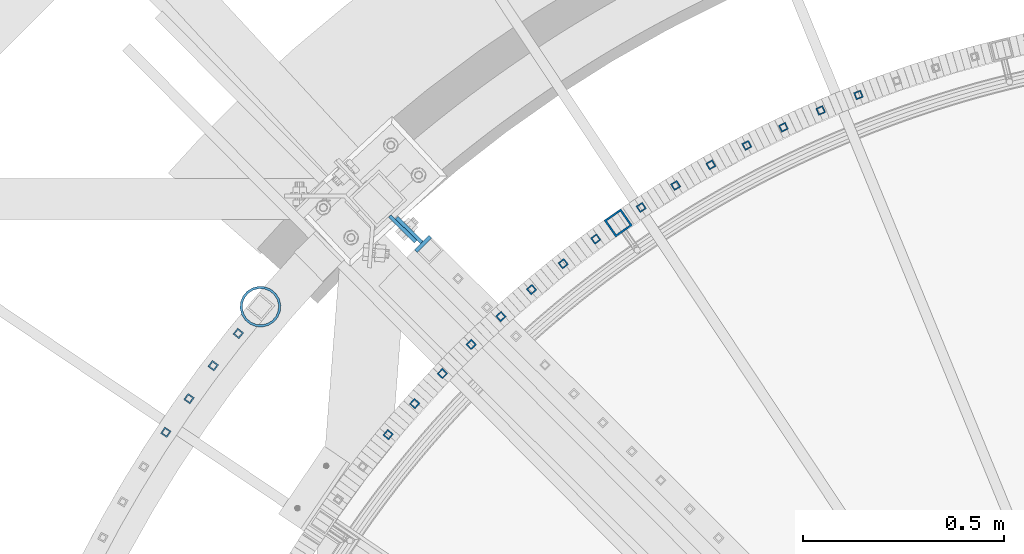
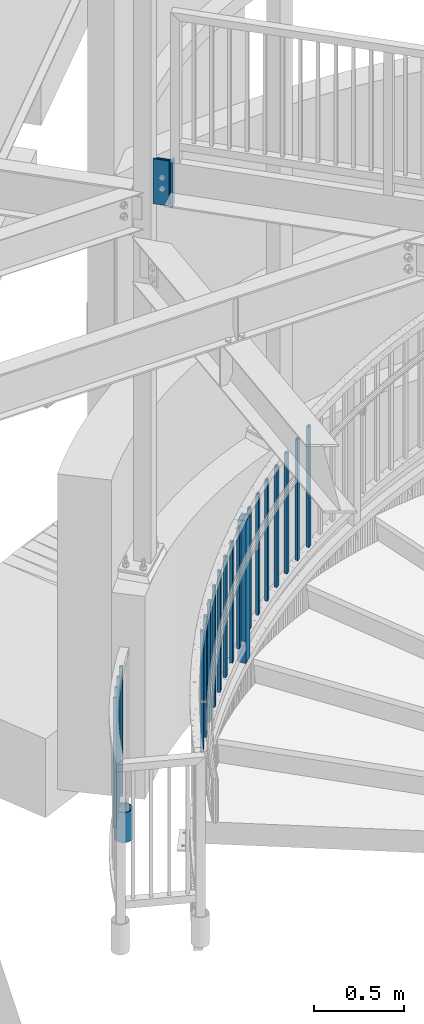
# One storey, part 263 of 975: 24 columns.
"""IFC2X3 building model written with IfcOpenShell, lengths in millimetres."""

from ifc_helpers import new_model, si_unit, frame, origin_with_axes, place, context, subcontext, project, spatial, faceted_brep, material, type_object, element, save


model = new_model("IFC2X3")

# Units and contexts
model_context = context("Model", 3, precision=1e-05, world=origin_with_axes())
body_context = subcontext(model_context, "Body", "Model", "MODEL_VIEW")
ifc_project = project(units=[si_unit("LENGTHUNIT", "METRE", prefix="MILLI"), si_unit("AREAUNIT", "SQUARE_METRE"), si_unit("VOLUMEUNIT", "CUBIC_METRE"), si_unit("MASSUNIT", "GRAM", prefix="KILO"), si_unit("TIMEUNIT", "SECOND"), si_unit("PLANEANGLEUNIT", "RADIAN"), si_unit("SOLIDANGLEUNIT", "STERADIAN"), si_unit("THERMODYNAMICTEMPERATUREUNIT", "DEGREE_CELSIUS"), si_unit("LUMINOUSINTENSITYUNIT", "LUMEN")], contexts=[model_context])

# Site, building, storey
site_placement = place(None, origin_with_axes())
site = spatial("IfcSite", under=ifc_project, at=site_placement, CompositionType="ELEMENT")
building_placement = place(site_placement, origin_with_axes())
building = spatial("IfcBuilding", under=site, at=building_placement, Name="Undefined", CompositionType="ELEMENT")
storey_placement = place(building_placement, origin_with_axes())
storey = spatial("IfcBuildingStorey", under=building, at=storey_placement, Name="Undefined", CompositionType="ELEMENT", Elevation=0.0)

# Columns
ifc_material_1 = material(Name="STEEL/A36")
column_type_1 = type_object("IfcColumnType", PredefinedType="NOTDEFINED")
column_1_placement = place(storey_placement, frame((32575.8374756472, 5742.26202919951, 3835.4), z_axis=(-0.708992011834517, 0.705216510835392, 0.0), x_axis=(0.0, 0.0, 1.0)))
element("IfcColumn", 1, at=column_1_placement, inside=storey, type_object=column_type_1, material=ifc_material_1, Name="PLATE", context=body_context, shape_type="Brep", body=[
    faceted_brep([(0.0, 4.76250000000073, -44.093499999999), (0.0, 4.76250000000073, 44.093499999999), (304.8, 4.762500000008, 44.0934999999845), (304.8, 4.76249999999345, -44.0934999999881), (0.0, -4.76250000000073, 44.093499999999), (304.8, -4.76249999999709, 44.0934999999918), (0.0, -4.76250000000073, -44.093499999999), (304.8, -4.762500000008, -44.0934999999772)], [[[0, 1, 2, 3]], [[1, 4, 5, 2]], [[4, 6, 7, 5]], [[6, 0, 3, 7]], [[5, 7, 3, 2]], [[6, 4, 1, 0]]]),
])
column_type_2 = type_object("IfcColumnType", PredefinedType="NOTDEFINED")
column_2_placement = place(storey_placement, frame((32559.3007490176, 5745.27612896161, 3835.4), z_axis=(-0.708992011834517, 0.705216510835392, 0.0), x_axis=(0.0, 0.0, 1.0)))
element("IfcColumn", 2, at=column_2_placement, inside=storey, type_object=column_type_2, material=ifc_material_1, Name="PLATE", context=body_context, shape_type="Brep", body=[
    faceted_brep([(0.0, 4.76250000000073, -45.2435000000005), (0.0, 4.76250000000073, 45.2435000000005), (304.8, 4.762500000008, 45.2434999999859), (304.8, 4.76249999999345, -45.2434999999859), (0.0, -4.76250000000073, 45.2435000000005), (304.8, -4.76249999999709, 45.2434999999932), (0.0, -4.76250000000073, -45.2435000000005), (304.8, -4.76250000001164, -45.2434999999787)], [[[0, 1, 2, 3]], [[1, 4, 5, 2]], [[4, 6, 7, 5]], [[6, 0, 3, 7]], [[5, 7, 3, 2]], [[6, 4, 1, 0]]]),
])
ifc_material_2 = material()
column_type_3 = type_object("IfcColumnType", Name="HSS3/4X3/4X.120_TUBES", PredefinedType="NOTDEFINED")
for number, where, z_axis, x_axis, name in (
    (3, (33039.5905282683, 5719.91818251176, 642.801552251104), (-0.589946465794102, 0.80744236171819, 0.0), (0.0, 0.0, 1.0), "PICKET"),
    (4, (32958.6825243406, 5658.48809769864, 610.536461137443), (-0.618150632862125, 0.786059663824671, 0.0), (0.0, 0.0, 1.0), "PICKET"),
    (5, (32879.9990778334, 5594.23332616015, 578.212699961467), (-0.645580445968539, 0.763692272962783, 0.0), (0.0, 0.0, 1.0), "PICKET"),
    (6, (32803.6387550955, 5527.23435951821, 545.922109874679), (-0.672201544826061, 0.740368207808423, 0.0), (0.0, 0.0, 1.0), "PICKET"),
    (7, (32729.6972123107, 5457.57512703381, 513.60287023605), (-0.697980579689669, 0.716116687681606, 0.0), (0.0, 0.0, 1.0), "PICKET"),
    (8, (32658.2670756693, 5385.34289046929, 481.30547755455), (-0.722885257856924, 0.690968091863242, 0.0), (0.0, 0.0, 1.0), "PICKET"),
    (9, (32589.4378253363, 5310.62813477601, 449.021547286682), (-0.746884381140134, 0.664953924124761, 0.0), (0.0, 0.0, 1.0), "PICKET"),
    (10, (32523.2956833595, 5233.5244547442, 416.686528038317), (-0.769947887041649, 0.638106771034519, 0.0), (0.0, 0.0, 1.0), "PICKET"),
    (11, (33692.9282264819, 6078.14225627673, 880.662732348244), (-0.363737540062124, 0.931501477159084, 0.0), (0.0, 0.0, 1.0), "PICKET"),
    (12, (33598.9342131206, 6039.60803937858, 848.317420348244), (-0.39647358286898, 0.918046130696619, 0.0), (0.0, 0.0, 1.0), "PICKET"),
    (13, (33506.3627171815, 5997.77170876383, 815.972108348244), (-0.428712966087704, 0.903440752184826, 0.0), (0.0, 0.0, 1.0), "PICKET"),
    (14, (33415.3297025015, 5952.68567258872, 783.626796348244), (-0.460415301767585, 0.887703638551889, 0.0), (0.0, 0.0, 1.0), "PICKET"),
    (15, (33325.94920567, 5904.40640989895, 751.281484348244), (-0.491540877965497, 0.870854502938871, 0.0), (0.0, 0.0, 1.0), "PICKET"),
    (16, (33238.3331931757, 5852.99439987862, 718.936172348244), (-0.522050703278448, 0.852914452454921, 0.0), (0.0, 0.0, 1.0), "PICKET"),
):
    element("IfcColumn", number, at=place(storey_placement, frame(where, z_axis=z_axis, x_axis=x_axis)), inside=storey, type_object=column_type_3, material=ifc_material_2, Name=name, ObjectType="HSS3/4X3/4X.120_TUBES", context=body_context, shape_type="Brep", body=[
        faceted_brep([(48.9778304891588, 6.35000000000036, -6.34999999999854), (44.9444858438005, -6.35000000000582, -6.34999999999127), (858.946568247068, -6.35000000000582, -6.34999999999127), (863.063419332087, 6.35000000000036, -6.34999999999854), (44.9444858438051, -6.35000000000036, 6.35000000000582), (858.946568247072, -6.35000000000036, 6.35000000000582), (48.9778304891634, 6.350000000004, 6.34999999999854), (863.063419332091, 6.350000000004, 6.34999999999854), (49.9861666504976, 9.52499999999964, -9.52500000000146), (49.9861666505039, 9.52500000000691, 9.52499999999418), (864.092632103347, 9.52500000000691, 9.52499999999418), (864.09263210334, 9.52499999999964, -9.52500000000146), (43.9361496824667, -9.52500000000146, 9.52500000001601), (857.917355475819, -9.52500000000146, 9.52500000001601), (43.9361496824599, -9.52500000000691, -9.52499999997963), (857.917355475812, -9.52500000000691, -9.52499999997963)], [[[0, 1, 2, 3]], [[1, 4, 5, 2]], [[4, 6, 7, 5]], [[6, 0, 3, 7]], [[8, 9, 10, 11]], [[9, 12, 13, 10]], [[12, 14, 15, 13]], [[14, 8, 11, 15]], [[13, 15, 11, 10], [5, 7, 3, 2]], [[14, 12, 9, 8], [6, 4, 1, 0]]]),
    ])
for number, where, z_axis, x_axis, name in (
    (17, (32150.7146531717, 5485.02926786868, 139.7), (-0.778747043975352, 0.627338059980144, 0.0), (0.0, 0.0, 1.0), "PICKET"),
    (18, (32088.1813407231, 5404.92257999241, 139.7), (-0.797594441800181, 0.603194086848882, 0.0), (0.0, 0.0, 1.0), "PICKET"),
    (19, (32028.1306877762, 5322.93833950091, 139.7), (-0.815693572944349, 0.578484221960532, 0.0), (0.0, 0.0, 1.0), "PICKET"),
    (20, (31970.6190312064, 5239.15346039429, 139.7), (-0.833027455272608, 0.553231650181046, 0.0), (0.0, 0.0, 1.0), "PICKET"),
):
    element("IfcColumn", number, at=place(storey_placement, frame(where, z_axis=z_axis, x_axis=x_axis)), inside=storey, type_object=column_type_3, material=ifc_material_2, Name=name, ObjectType="HSS3/4X3/4X.120_TUBES", context=body_context, shape_type="Brep", body=[
        faceted_brep([(0.0, 6.34999999998763, -6.34999999998763), (0.0, -6.35000000000582, -6.34999999998763), (876.3, -6.35000000000218, -6.3500000000131), (876.3, 6.34999999999854, -6.35000000000946), (0.0, -6.34999999998763, 6.34999999998763), (876.3, -6.34999999999854, 6.34999999999127), (0.0, 6.35000000000946, 6.34999999998763), (876.3, 6.35000000000582, 6.34999999999491), (0.0, 9.52499999997963, -9.52499999997963), (0.0, 9.52500000000873, 9.5249999999869), (876.3, 9.52500000000146, 9.52499999999418), (876.3, 9.52499999999782, -9.52500000001237), (0.0, -9.52499999997963, 9.52499999998327), (876.3, -9.52499999999782, 9.52499999999054), (0.0, -9.52500000000873, -9.5249999999869), (876.3, -9.52500000000146, -9.52500000001237)], [[[0, 1, 2, 3]], [[1, 4, 5, 2]], [[4, 6, 7, 5]], [[6, 0, 3, 7]], [[8, 9, 10, 11]], [[9, 12, 13, 10]], [[12, 14, 15, 13]], [[14, 8, 11, 15]], [[13, 15, 11, 10], [5, 7, 3, 2]], [[14, 12, 9, 8], [6, 4, 1, 0]]]),
    ])
column_3_placement = place(storey_placement, frame((33152.5914211472, 5798.51404608834, 686.590860348244), z_axis=(-0.551906558307154, 0.8339059604641, 0.0), x_axis=(0.0, 0.0, 1.0)))
element("IfcColumn", 21, at=column_3_placement, inside=storey, type_object=column_type_3, material=ifc_material_2, Name="PICKET", ObjectType="HSS3/4X3/4X.120_TUBES", context=body_context, shape_type="Brep", body=[
    faceted_brep([(48.9778304891588, 6.35000000000036, -6.34999999999854), (44.9444858438005, -6.35000000000582, -6.34999999999127), (858.946568247068, -6.35000000000582, -6.34999999999127), (863.063419332087, 6.35000000000036, -6.34999999999854), (44.9444858438051, -6.35000000000036, 6.35000000000582), (858.946568247072, -6.35000000000036, 6.35000000000582), (48.9778304891634, 6.350000000004, 6.34999999999854), (863.063419332091, 6.350000000004, 6.34999999999854), (49.9861666504976, 9.52499999999964, -9.52500000000146), (49.9861666505039, 9.52500000000691, 9.52499999999418), (864.092632103347, 9.52500000000691, 9.52499999999418), (864.09263210334, 9.52499999999964, -9.52500000000146), (43.9361496824667, -9.52500000000146, 9.52500000001601), (857.917355475819, -9.52500000000146, 9.52500000001601), (43.9361496824599, -9.52500000000691, -9.52499999997963), (857.917355475812, -9.52500000000691, -9.52499999997963)], [[[0, 1, 2, 3]], [[1, 4, 5, 2]], [[4, 6, 7, 5]], [[6, 0, 3, 7]], [[8, 9, 10, 11]], [[9, 12, 13, 10]], [[12, 14, 15, 13]], [[14, 8, 11, 15]], [[13, 15, 11, 10], [5, 7, 3, 2]], [[14, 12, 9, 8], [6, 4, 1, 0]]]),
])
column_type_4 = type_object("IfcColumnType", Name="HSS2X2X.188_TUBES", PredefinedType="NOTDEFINED")
column_4_placement = place(storey_placement, frame((33095.6153176469, 5759.89052494561, 512.248814239551), z_axis=(-0.571000168249575, 0.820949942358825, 0.0), x_axis=(0.0, 0.0, 1.0)))
element("IfcColumn", 22, at=column_4_placement, inside=storey, type_object=column_type_4, material=ifc_material_2, Name="HANDRAIL", ObjectType="HSS2X2X.188_TUBES", context=body_context, shape_type="Brep", body=[
    faceted_brep([(59.7770034089217, 20.6374999999425, -20.6375000000444), (46.6339334019876, -20.6375000000517, -20.6375000000335), (1006.79125658838, -20.6375000000517, -20.6375000000335), (1019.96851403156, 20.6374999999425, -20.6375000000444), (46.6339334020035, -20.6374999999389, 20.637500000048), (1006.7912565884, -20.6374999999389, 20.637500000048), (59.7770034089381, 20.6375000000517, 20.6375000000335), (1019.96851403158, 20.6375000000517, 20.6375000000335), (61.2935114866432, 25.3999999999287, -25.4000000000524), (61.2935114866632, 25.4000000000633, 25.4000000000415), (1021.48896681348, 25.4000000000633, 25.4000000000415), (1021.48896681346, 25.3999999999287, -25.4000000000524), (45.1174253242825, -25.3999999999251, 25.400000000056), (1005.27080380649, -25.3999999999251, 25.400000000056), (45.1174253242625, -25.4000000000597, -25.4000000000415), (1005.27080380647, -25.4000000000597, -25.4000000000415)], [[[0, 1, 2, 3]], [[1, 4, 5, 2]], [[4, 6, 7, 5]], [[6, 0, 3, 7]], [[8, 9, 10, 11]], [[9, 12, 13, 10]], [[12, 14, 15, 13]], [[14, 8, 11, 15]], [[13, 15, 11, 10], [5, 7, 3, 2]], [[14, 12, 9, 8], [6, 4, 1, 0]]]),
])
ifc_material_3 = material(Name="STEEL/A53")
column_type_5 = type_object("IfcColumnType", Name="PIPE3-1/2STD", PredefinedType="NOTDEFINED")
column_5_placement = place(storey_placement, frame((32205.7855764118, 5551.59857529668, -203.2), z_axis=(0.0811383310017991, -0.996702850022133, -8.3212189281312e-09), x_axis=(0.0, 0.0, 1.0)))
element("IfcColumn", 23, at=column_5_placement, inside=storey, type_object=column_type_5, material=ifc_material_3, ObjectType="PIPE3-1/2STD", context=body_context, shape_type="Brep", body=[
    faceted_brep([(0.0, -45.0595999999932, 1.45519152283669e-11), (0.0, -42.8542262016344, 13.924182159768), (203.199999999991, -42.8542262017145, 13.9241821598171), (203.19999999999, -45.0596000000478, 5.82076609134674e-11), (0.0, -36.45398215971, 26.4853683542424), (203.199999999993, -36.45398215981, 26.4853683542988), (0.0, -26.4853683541623, 36.45398215979), (203.199999999995, -26.4853683542788, 36.4539821598537), (0.0, -13.9241821596988, 42.8542262017108), (203.199999999998, -13.9241821598262, 42.8542262017836), (0.0, 3.63797880709171e-11, 45.0596000000514), (203.2, -9.27684595808387e-11, 45.0596000001387), (0.0, 13.9241821597716, 42.8542262017036), (203.200000000003, 13.9241821596443, 42.8542262017927), (0.0, 26.4853683542242, 36.4539821597718), (203.200000000006, 26.4853683541096, 36.4539821598701), (0.0, 36.4539821597537, 26.4853683542206), (203.200000000008, 36.4539821596554, 26.4853683543224), (0.0, 42.8542262016563, 13.9241821597425), (203.200000000009, 42.8542262015817, 13.9241821598443), (0.0, 45.0595999999932, -1.09139364212751e-11), (203.200000000009, 45.0595999999423, 8.9130480773747e-11), (0.0, 42.8542262016344, -13.9241821597643), (203.200000000008, 42.854226201609, -13.9241821596697), (0.0, 36.45398215971, -26.4853683542387), (203.200000000007, 36.4539821597045, -26.4853683541514), (0.0, 26.4853683541623, -36.4539821597864), (203.200000000004, 26.4853683541733, -36.4539821597064), (0.0, 13.9241821596988, -42.8542262017072), (203.200000000002, 13.9241821597225, -42.8542262016381), (0.0, -3.63797880709171e-11, -45.0596000000478), (203.199999999999, -9.09494701772928e-12, -45.0595999999914), (0.0, -13.9241821597716, -42.8542262016963), (203.199999999996, -13.9241821597479, -42.8542262016472), (0.0, -26.4853683542242, -36.4539821597682), (203.199999999993, -26.4853683542133, -36.4539821597227), (0.0, -36.4539821597537, -26.4853683542169), (203.199999999992, -36.4539821597609, -26.4853683541751), (0.0, -42.8542262016563, -13.9241821597352), (203.199999999991, -42.8542262016872, -13.924182159697), (0.0, -50.799999999992, 1.81898940354586e-11), (0.0, -48.3136710278013, -15.6980633142484), (203.199999999989, -48.313671027825, -15.6980633142139), (203.199999999989, -50.8000000000466, 5.63886715099216e-11), (0.0, -41.0980633142644, -29.8594908164741), (203.19999999999, -41.0980633142663, -29.8594908164414), (0.0, -29.859490816485, -41.0980633142826), (203.199999999993, -29.8594908164687, -41.0980633142426), (0.0, -15.6980633142848, -48.313671027845), (203.199999999995, -15.6980633142539, -48.313671027794), (0.0, -4.36557456851006e-11, -50.8000000000575), (203.199999999998, -7.27595761418343e-12, -50.7999999999993), (0.0, 15.6980633142011, -48.3136710278523), (203.200000000002, 15.6980633142375, -48.3136710277831), (0.0, 29.8594908164159, -41.0980633143045), (203.200000000005, 29.8594908164378, -41.0980633142226), (0.0, 41.0980633142135, -29.8594908165032), (203.200000000008, 41.0980633142171, -29.8594908164141), (0.0, 48.3136710277722, -15.6980633142775), (203.200000000009, 48.3136710277504, -15.6980633141811), (0.0, 50.799999999992, -1.45519152283669e-11), (203.20000000001, 50.7999999999411, 9.09494701772928e-11), (0.0, 48.313671027794, 15.6980633142521), (203.20000000001, 48.3136710277213, 15.6980633143594), (0.0, 41.0980633142644, 29.8594908164814), (203.200000000008, 41.0980633141626, 29.8594908165887), (0.0, 29.859490816485, 41.0980633142863), (203.200000000007, 29.8594908163632, 41.0980633143899), (0.0, 15.6980633142848, 48.3136710278486), (203.200000000004, 15.6980633141484, 48.3136710279414), (0.0, 4.00177668780088e-11, 50.8000000000611), (203.200000000001, -9.82254277914762e-11, 50.8000000001466), (0.0, -15.6980633142011, 48.3136710278559), (203.199999999997, -15.698063314343, 48.3136710279305), (0.0, -29.8594908164159, 41.0980633143081), (203.199999999994, -29.8594908165433, 41.0980633143681), (0.0, -41.0980633142171, 29.8594908165069), (203.199999999992, -41.0980633143226, 29.8594908165596), (0.0, -48.3136710277722, 15.6980633142812), (203.19999999999, -48.3136710278559, 15.6980633143285)], [[[0, 1, 2, 3]], [[1, 4, 5, 2]], [[4, 6, 7, 5]], [[6, 8, 9, 7]], [[8, 10, 11, 9]], [[10, 12, 13, 11]], [[12, 14, 15, 13]], [[14, 16, 17, 15]], [[16, 18, 19, 17]], [[18, 20, 21, 19]], [[20, 22, 23, 21]], [[22, 24, 25, 23]], [[24, 26, 27, 25]], [[26, 28, 29, 27]], [[28, 30, 31, 29]], [[30, 32, 33, 31]], [[32, 34, 35, 33]], [[34, 36, 37, 35]], [[36, 38, 39, 37]], [[38, 0, 3, 39]], [[40, 41, 42, 43]], [[41, 44, 45, 42]], [[44, 46, 47, 45]], [[46, 48, 49, 47]], [[48, 50, 51, 49]], [[50, 52, 53, 51]], [[52, 54, 55, 53]], [[54, 56, 57, 55]], [[56, 58, 59, 57]], [[58, 60, 61, 59]], [[60, 62, 63, 61]], [[62, 64, 65, 63]], [[64, 66, 67, 65]], [[66, 68, 69, 67]], [[68, 70, 71, 69]], [[70, 72, 73, 71]], [[72, 74, 75, 73]], [[74, 76, 77, 75]], [[76, 78, 79, 77]], [[78, 40, 43, 79]], [[45, 47, 49, 51, 53, 55, 57, 59, 61, 63, 65, 67, 69, 71, 73, 75, 77, 79, 43, 42], [5, 7, 9, 11, 13, 15, 17, 19, 21, 23, 25, 27, 29, 31, 33, 35, 37, 39, 3, 2]], [[78, 76, 74, 72, 70, 68, 66, 64, 62, 60, 58, 56, 54, 52, 50, 48, 46, 44, 41, 40], [38, 36, 34, 32, 30, 28, 26, 24, 22, 20, 18, 16, 14, 12, 10, 8, 6, 4, 1, 0]]]),
])
column_type_6 = type_object("IfcColumnType", PredefinedType="NOTDEFINED")
column_6_placement = place(storey_placement, frame((32610.4759893774, 5707.80797134617, 3835.4), z_axis=(0.705216510835394, 0.708992011834514, 0.0), x_axis=(0.0, 0.0, 1.0)))
element("IfcColumn", 24, at=column_6_placement, inside=storey, type_object=column_type_6, material=ifc_material_1, Name="PLATE", context=body_context, shape_type="Brep", body=[
    faceted_brep([(0.0, 4.7624999999789, -25.4000000000087), (0.0, 4.76250000001528, 25.4000000000087), (304.8, 4.76250000001528, 25.4000000000087), (304.8, 4.7624999999789, -25.4000000000087), (0.0, -4.7624999999789, 25.4000000000087), (304.8, -4.7624999999789, 25.4000000000087), (0.0, -4.76250000001892, -25.4000000000087), (304.8, -4.76250000001892, -25.4000000000087)], [[[0, 1, 2, 3]], [[1, 4, 5, 2]], [[4, 6, 7, 5]], [[6, 0, 3, 7]], [[5, 7, 3, 2]], [[6, 4, 1, 0]]]),
])

save(model, "model.ifc")
